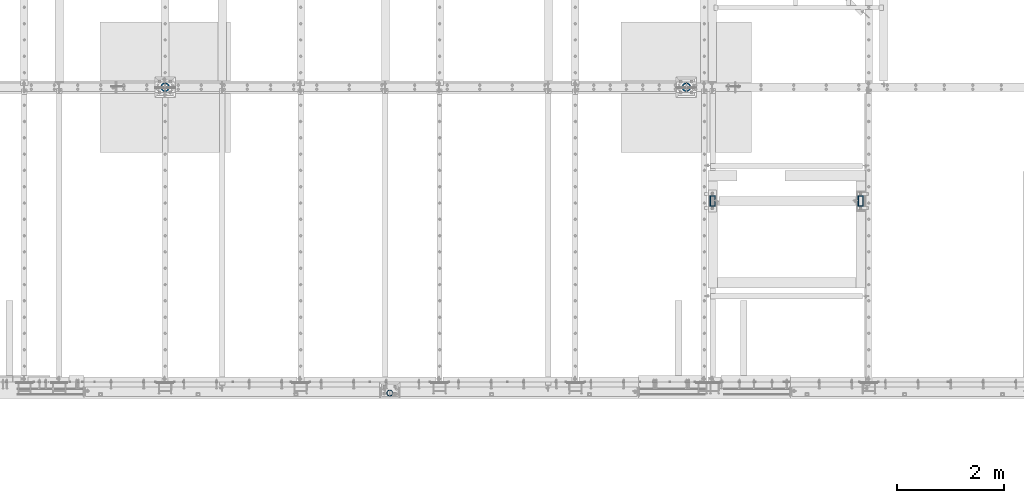
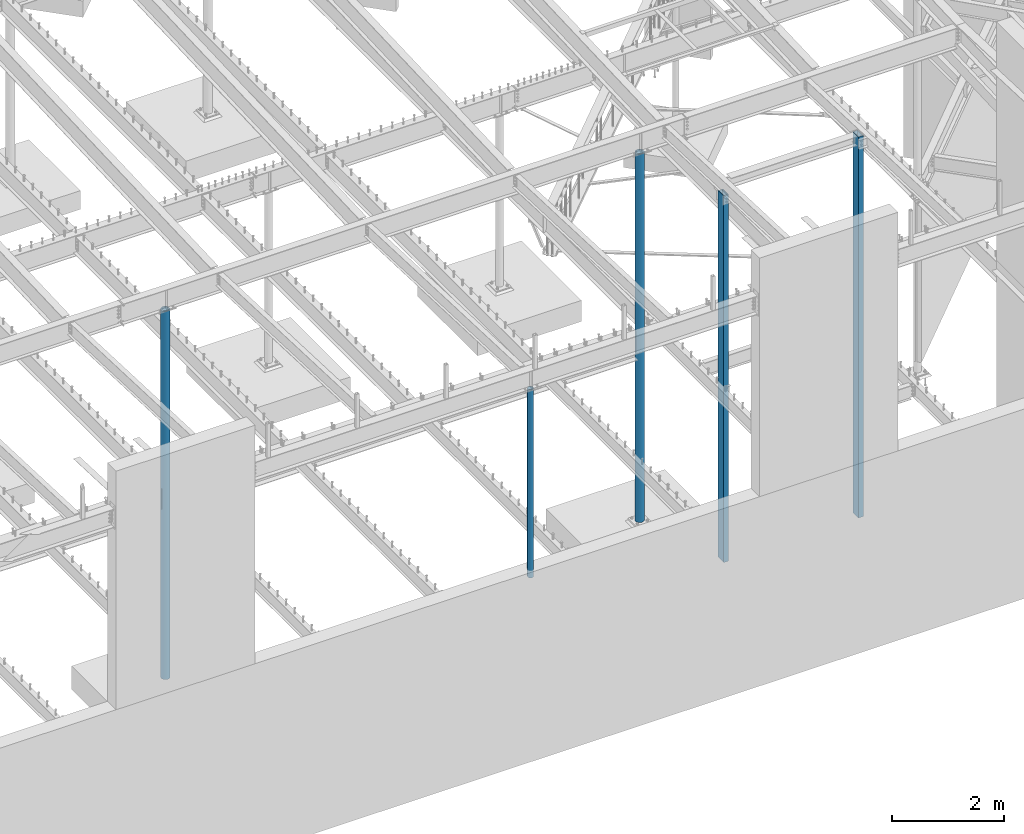
# One storey, part 122 of 975: 5 columns.
"""IFC2X3 building model written with IfcOpenShell, lengths in millimetres."""

import ifcopenshell
import ifcopenshell.guid

model = None  # the IFC model being written
_history = None  # IfcOwnerHistory: only IFC2X3 demands one
_inside = {}  # id of a spatial element -> (the spatial element, [elements in it])
_under = {}  # id of a project, library or spatial element -> (it, [spatial elements below it])
_declared = {}  # id of a project -> (the project, [libraries it declares])
_typed = {}  # id of a type object -> (the type object, [elements of that type])
_made_of = {}  # id of a material, layer set ... -> (it, [elements and type objects made of it])


def new_model(schema):
    """Start an empty IFC model of exactly this schema.

    Asked for "IFC4X3", IfcOpenShell would pick the latest addendum, in which some entities
    have other attributes; the version numbers below select the first issue.
    IFC2X3 requires an IfcOwnerHistory on every rooted entity: one is made here for all.
    """
    global model, _history
    if schema == "IFC4X3":
        model = ifcopenshell.file(schema_version=(4, 3, 0, 0))
    else:
        model = ifcopenshell.file(schema=schema)
    _inside.clear()
    _under.clear()
    _declared.clear()
    _typed.clear()
    _made_of.clear()
    _history = None
    if model.schema == "IFC2X3":
        org = make("IfcOrganization", Name="unknown")
        user = make(
            "IfcPersonAndOrganization",
            ThePerson=make("IfcPerson", FamilyName="unknown"),
            TheOrganization=org,
        )
        app = make(
            "IfcApplication",
            ApplicationDeveloper=org,
            Version="unknown",
            ApplicationFullName="unknown",
            ApplicationIdentifier="unknown",
        )
        _history = make(
            "IfcOwnerHistory",
            OwningUser=user,
            OwningApplication=app,
            ChangeAction="ADDED",
            CreationDate=0,
        )
    return model


def make(cls, **values):
    """One entity of the class cls with the attributes given. An attribute that is None is left unset."""
    return model.create_entity(
        cls, **{name: value for name, value in values.items() if value is not None}
    )


def rooted(cls, **values):
    """An entity with a GlobalId (a new one), such as an element, a storey or a relation."""
    return make(cls, GlobalId=ifcopenshell.guid.new(), OwnerHistory=_history, **values)


def si_unit(unit_type, name, prefix=None):
    """IfcSIUnit, for example si_unit("LENGTHUNIT", "METRE", prefix="MILLI")."""
    return make("IfcSIUnit", UnitType=unit_type, Prefix=prefix, Name=name)


def assignment(units):
    """IfcUnitAssignment: the units of a project."""
    return None if units is None else make("IfcUnitAssignment", Units=units)


def point(xyz):
    """IfcCartesianPoint."""
    return None if xyz is None else make("IfcCartesianPoint", Coordinates=xyz)


def direction(xyz):
    """IfcDirection."""
    return None if xyz is None else make("IfcDirection", DirectionRatios=xyz)


def frame(location, z_axis=None, x_axis=None):
    """IfcAxis2Placement3D, a coordinate frame: its origin and axes. An axis left out is left unset."""
    return make(
        "IfcAxis2Placement3D",
        Location=point(location),
        Axis=direction(z_axis),
        RefDirection=direction(x_axis),
    )


def origin_with_axes():
    """The frame at (0, 0, 0) with the z axis (0, 0, 1) and the x axis (1, 0, 0) written out."""
    return frame((0.0, 0.0, 0.0), z_axis=(0.0, 0.0, 1.0), x_axis=(1.0, 0.0, 0.0))


def place(relative_to, where):
    """IfcLocalPlacement: puts the frame where relative to a parent placement (None: the world)."""
    return make(
        "IfcLocalPlacement", PlacementRelTo=relative_to, RelativePlacement=where
    )


def context(
    kind, dimensions, precision=None, world=None, true_north=None, identifier=None
):
    """IfcGeometricRepresentationContext, for example the 3D "Model" context."""
    return make(
        "IfcGeometricRepresentationContext",
        ContextIdentifier=identifier,
        ContextType=kind,
        CoordinateSpaceDimension=dimensions,
        Precision=precision,
        WorldCoordinateSystem=world,
        TrueNorth=true_north,
    )


def subcontext(parent, identifier, kind, view, scale=None):
    """IfcGeometricRepresentationSubContext, for example "Body" below "Model"."""
    return make(
        "IfcGeometricRepresentationSubContext",
        ContextIdentifier=identifier,
        ContextType=kind,
        ParentContext=parent,
        TargetScale=scale,
        TargetView=view,
    )


def project(units=None, contexts=None):
    """IfcProject with its units and contexts."""
    return rooted(
        "IfcProject",
        Name="project",
        RepresentationContexts=contexts,
        UnitsInContext=assignment(units),
    )


def spatial(cls, under=None, at=None, **own):
    """A site, building, storey or space (cls), placed at a placement, below another one or the project."""
    s = rooted(cls, ObjectPlacement=at, **own)
    if under is not None:
        _under.setdefault(under.id(), (under, []))[1].append(s)
    return s


def faces_of(points, faces, orient=None, outer=None):
    """IfcFace entities. A face is a list of loops; a loop is a list of indices into points, from 0.

    orient and outer hold one flag for each loop. By default every Orientation is true, the
    first loop of a face is its IfcFaceOuterBound and the others are IfcFaceBound.
    """
    made = []
    for i, loops in enumerate(faces):
        bounds = []
        for j, loop in enumerate(loops):
            is_outer = j == 0 if outer is None else outer[i][j]
            bounds.append(
                make(
                    "IfcFaceOuterBound" if is_outer else "IfcFaceBound",
                    Bound=make("IfcPolyLoop", Polygon=[points[k] for k in loop]),
                    Orientation=True if orient is None else orient[i][j],
                )
            )
        made.append(make("IfcFace", Bounds=bounds))
    return made


def faceted_brep(points, faces, orient=None, outer=None, voids=None):
    """IfcFacetedBrep: a solid bounded by flat faces; with voids (closed shells), ...WithVoids."""
    shared = [point(p) for p in points]
    hull = make("IfcClosedShell", CfsFaces=faces_of(shared, faces, orient, outer))
    if voids is None:
        return make("IfcFacetedBrep", Outer=hull)
    return make(
        "IfcFacetedBrepWithVoids",
        Outer=hull,
        Voids=[
            make(cls, CfsFaces=faces_of(shared, fs, o, b)) for cls, fs, o, b in voids
        ],
    )


def shape(context_of_items, identifier, shape_type, items):
    """IfcShapeRepresentation: the items that make up one representation, for example the "Body"."""
    return make(
        "IfcShapeRepresentation",
        ContextOfItems=context_of_items,
        RepresentationIdentifier=identifier,
        RepresentationType=shape_type,
        Items=items,
    )


def material(Name=None, Category=None):
    """IfcMaterial."""
    return make("IfcMaterial", Name=Name, Category=Category)


def made_of(thing, what):
    """Note that an element or type object is made of a material, layer set ...; save() writes the relation."""
    if what is not None:
        _made_of.setdefault(what.id(), (what, []))[1].append(thing)
    return thing


def type_object(cls, material=None, **own):
    """A type object (cls), such as IfcWallType, which elements share."""
    return made_of(rooted(cls, **own), material)


def element(
    cls,
    number,
    at=None,
    inside=None,
    cuts=None,
    type_object=None,
    material=None,
    context=None,
    identifier="Body",
    shape_type=None,
    held_by="IfcProductDefinitionShape",
    body=None,
    shapes=None,
    **own,
):
    """One element of the class cls, such as IfcWall. Its Tag is "e" and its number.

    at: its placement. inside: the storey or other place that contains it. cuts: it is an
    opening in that element (IfcRelVoidsElement). A single representation is given by context,
    identifier, shape_type and body (its items); several are given by shapes. held_by: the class
    of the entity that holds the representations. save() writes the other relations.
    """
    e = rooted(cls, Tag="e%d" % number, ObjectPlacement=at, **own)
    if body is not None:
        shapes = [shape(context, identifier, shape_type, body)]
    if shapes is not None:
        e.Representation = make(held_by, Representations=shapes)
    if inside is not None:
        _inside.setdefault(inside.id(), (inside, []))[1].append(e)
    if cuts is not None:
        rooted(
            "IfcRelVoidsElement", RelatingBuildingElement=cuts, RelatedOpeningElement=e
        )
    if type_object is not None:
        _typed.setdefault(type_object.id(), (type_object, []))[1].append(e)
    return made_of(e, material)


def aggregate(whole, parts):
    """IfcRelAggregates: a whole, such as a stair, and the parts it consists of."""
    return rooted("IfcRelAggregates", RelatingObject=whole, RelatedObjects=parts)


def save(model, path):
    """Write the relations noted so far, then the file.

    IfcRelAggregates (storeys below a building ...), IfcRelContainedInSpatialStructure (elements
    in a storey), IfcRelDefinesByType, IfcRelAssociatesMaterial and IfcRelDeclares: one each for
    every whole, place, type object, material and project.
    """
    for whole, parts in _under.values():
        aggregate(whole, parts)
    for where, things in _inside.values():
        rooted(
            "IfcRelContainedInSpatialStructure",
            RelatedElements=things,
            RelatingStructure=where,
        )
    for kind, things in _typed.values():
        rooted("IfcRelDefinesByType", RelatedObjects=things, RelatingType=kind)
    for what, things in _made_of.values():
        rooted("IfcRelAssociatesMaterial", RelatedObjects=things, RelatingMaterial=what)
    for by, libraries in _declared.values():
        rooted("IfcRelDeclares", RelatingContext=by, RelatedDefinitions=libraries)
    model.write(path)


model = new_model("IFC2X3")

# Units and contexts
model_context = context("Model", 3, precision=1e-05, world=origin_with_axes())
body_context = subcontext(model_context, "Body", "Model", "MODEL_VIEW")
ifc_project = project(units=[si_unit("LENGTHUNIT", "METRE", prefix="MILLI"), si_unit("AREAUNIT", "SQUARE_METRE"), si_unit("VOLUMEUNIT", "CUBIC_METRE"), si_unit("MASSUNIT", "GRAM", prefix="KILO"), si_unit("TIMEUNIT", "SECOND"), si_unit("PLANEANGLEUNIT", "RADIAN"), si_unit("SOLIDANGLEUNIT", "STERADIAN"), si_unit("THERMODYNAMICTEMPERATUREUNIT", "DEGREE_CELSIUS"), si_unit("LUMINOUSINTENSITYUNIT", "LUMEN")], contexts=[model_context])

# Site, building, storey
site_placement = place(None, origin_with_axes())
site = spatial("IfcSite", under=ifc_project, at=site_placement, CompositionType="ELEMENT")
building_placement = place(site_placement, origin_with_axes())
building = spatial("IfcBuilding", under=site, at=building_placement, Name="Undefined", CompositionType="ELEMENT")
storey_placement = place(building_placement, origin_with_axes())
storey = spatial("IfcBuildingStorey", under=building, at=storey_placement, Name="Undefined", CompositionType="ELEMENT", Elevation=0.0)

# Columns
ifc_material_1 = material(Name="STEEL/A53")
column_type_1 = type_object("IfcColumnType", Name="PIPE4STD", PredefinedType="NOTDEFINED")
column_1_placement = place(storey_placement, frame((17687.9249973829, 101.599999669799, 3937.0), z_axis=(0.0, 1.0, 0.0), x_axis=(0.0, 0.0, 1.0)))
element("IfcColumn", 1, at=column_1_placement, inside=storey, type_object=column_type_1, material=ifc_material_1, Name="COLUMN", ObjectType="PIPE4STD", context=body_context, shape_type="Brep", body=[
    faceted_brep([(19.0500000000025, -51.1301999999996, 0.0), (19.0500000000025, -48.6277098894743, 15.8001007257917), (4105.275, -48.6277098894752, 15.8001007257899), (4105.275, -51.1301999999996, 0.0), (19.0500000000025, -41.3652007257897, 30.0535775067656), (4105.275, -41.3652007257915, 30.0535775067646), (19.0500000000025, -30.0535775067647, 41.3652007257915), (4105.275, -30.0535775067656, 41.3652007257899), (19.0500000000025, -15.8001007257899, 48.6277098894752), (4105.275, -15.8001007257917, 48.6277098894745), (19.0500000000025, 0.0, 51.1301999999996), (4105.275, 0.0, 51.1302), (19.0500000000025, 15.8001007257899, 48.6277098894752), (4105.275, 15.8001007257917, 48.6277098894745), (19.0500000000025, 30.0535775067647, 41.3652007257915), (4105.275, 30.0535775067656, 41.3652007257899), (19.0500000000025, 41.3652007257897, 30.0535775067656), (4105.275, 41.3652007257915, 30.0535775067646), (19.0500000000025, 48.6277098894743, 15.8001007257917), (4105.275, 48.6277098894752, 15.8001007257899), (19.0500000000025, 51.1301999999996, 0.0), (4105.275, 51.1301999999996, 0.0), (19.0500000000025, 48.6277098894743, -15.8001007257917), (4105.275, 48.6277098894752, -15.8001007257899), (19.0500000000025, 41.3652007257897, -30.0535775067656), (4105.275, 41.3652007257915, -30.0535775067646), (19.0500000000025, 30.0535775067647, -41.3652007257915), (4105.275, 30.0535775067656, -41.3652007257899), (19.0500000000025, 15.8001007257899, -48.6277098894752), (4105.275, 15.8001007257917, -48.6277098894745), (19.0500000000025, 0.0, -51.1301999999996), (4105.275, 0.0, -51.1302), (19.0500000000025, -15.8001007257899, -48.6277098894752), (4105.275, -15.8001007257917, -48.6277098894745), (19.0500000000025, -30.0535775067647, -41.3652007257915), (4105.275, -30.0535775067656, -41.3652007257899), (19.0500000000025, -41.3652007257897, -30.0535775067656), (4105.275, -41.3652007257915, -30.0535775067646), (19.0500000000025, -48.6277098894743, -15.8001007257917), (4105.275, -48.6277098894752, -15.8001007257899), (19.0500000000025, -57.1499999999996, 0.0), (19.0500000000025, -54.3528799062678, -17.6603212285299), (4105.275, -54.3528799062697, -17.6603212285283), (4105.275, -57.1500000000015, 0.0), (19.0500000000025, -46.2353212285279, -33.5919271685161), (4105.275, -46.235321228527, -33.5919271685148), (19.0500000000025, -33.5919271685152, -46.235321228527), (4105.275, -33.5919271685161, -46.2353212285282), (19.0500000000025, -17.6603212285281, -54.3528799062697), (4105.275, -17.6603212285299, -54.352879906268), (19.0500000000025, 0.0, -57.1500000000015), (4105.275, 0.0, -57.15), (19.0500000000025, 17.6603212285281, -54.3528799062697), (4105.275, 17.6603212285299, -54.352879906268), (19.0500000000025, 33.5919271685152, -46.235321228527), (4105.275, 33.5919271685161, -46.2353212285282), (19.0500000000025, 46.2353212285279, -33.5919271685161), (4105.275, 46.235321228527, -33.5919271685148), (19.0500000000025, 54.3528799062678, -17.6603212285299), (4105.275, 54.3528799062697, -17.6603212285282), (19.0500000000025, 57.1499999999996, 0.0), (4105.275, 57.1500000000015, 0.0), (19.0500000000025, 54.3528799062678, 17.6603212285299), (4105.275, 54.3528799062697, 17.6603212285282), (19.0500000000025, 46.2353212285279, 33.5919271685161), (4105.275, 46.235321228527, 33.5919271685148), (19.0500000000025, 33.5919271685152, 46.235321228527), (4105.275, 33.5919271685161, 46.2353212285282), (19.0500000000025, 17.6603212285281, 54.3528799062697), (4105.275, 17.6603212285299, 54.352879906268), (19.0500000000025, 0.0, 57.1500000000015), (4105.275, 0.0, 57.15), (19.0500000000025, -17.6603212285281, 54.3528799062697), (4105.275, -17.6603212285299, 54.352879906268), (19.0500000000025, -33.5919271685152, 46.235321228527), (4105.275, -33.5919271685161, 46.2353212285282), (19.0500000000025, -46.2353212285279, 33.5919271685161), (4105.275, -46.235321228527, 33.5919271685148), (19.0500000000025, -54.3528799062678, 17.6603212285299), (4105.275, -54.3528799062697, 17.6603212285282)], [[[0, 1, 2, 3]], [[1, 4, 5, 2]], [[4, 6, 7, 5]], [[6, 8, 9, 7]], [[8, 10, 11, 9]], [[10, 12, 13, 11]], [[12, 14, 15, 13]], [[14, 16, 17, 15]], [[16, 18, 19, 17]], [[18, 20, 21, 19]], [[20, 22, 23, 21]], [[22, 24, 25, 23]], [[24, 26, 27, 25]], [[26, 28, 29, 27]], [[28, 30, 31, 29]], [[30, 32, 33, 31]], [[32, 34, 35, 33]], [[34, 36, 37, 35]], [[36, 38, 39, 37]], [[38, 0, 3, 39]], [[40, 41, 42, 43]], [[41, 44, 45, 42]], [[44, 46, 47, 45]], [[46, 48, 49, 47]], [[48, 50, 51, 49]], [[50, 52, 53, 51]], [[52, 54, 55, 53]], [[54, 56, 57, 55]], [[56, 58, 59, 57]], [[58, 60, 61, 59]], [[60, 62, 63, 61]], [[62, 64, 65, 63]], [[64, 66, 67, 65]], [[66, 68, 69, 67]], [[68, 70, 71, 69]], [[70, 72, 73, 71]], [[72, 74, 75, 73]], [[74, 76, 77, 75]], [[76, 78, 79, 77]], [[78, 40, 43, 79]], [[45, 47, 49, 51, 53, 55, 57, 59, 61, 63, 65, 67, 69, 71, 73, 75, 77, 79, 43, 42], [5, 7, 9, 11, 13, 15, 17, 19, 21, 23, 25, 27, 29, 31, 33, 35, 37, 39, 3, 2]], [[78, 76, 74, 72, 70, 68, 66, 64, 62, 60, 58, 56, 54, 52, 50, 48, 46, 44, 41, 40], [38, 36, 34, 32, 30, 28, 26, 24, 22, 20, 18, 16, 14, 12, 10, 8, 6, 4, 1, 0]]]),
])
ifc_material_2 = material()
column_type_2 = type_object("IfcColumnType", Name="HSS8X4X1/2", PredefinedType="NOTDEFINED")
column_2_placement = place(storey_placement, frame((26492.2, 3690.93747558594, 0.0), z_axis=(0.0, -1.0, 0.0), x_axis=(0.0, 0.0, 1.0)))
element("IfcColumn", 2, at=column_2_placement, inside=storey, type_object=column_type_2, material=ifc_material_2, Name="COLUMN", ObjectType="HSS8X4X1/2", context=body_context, shape_type="Brep", body=[
    faceted_brep([(38.1000000000063, 38.0999999999985, -88.9000000000001), (38.1000000000063, -38.0999999999985, -88.9000000000001), (8308.73594882392, -38.0999999999985, -88.9000000000001), (8308.73594882392, 38.0999999999985, -88.9000000000001), (38.1000000000063, -38.0999999999985, 88.9000000000001), (8308.73594882392, -38.0999999999985, 88.9000000000001), (38.1000000000063, 38.0999999999985, 88.9000000000001), (8308.73594882392, 38.0999999999985, 88.9000000000001), (38.1000000000063, 50.7999999999993, -101.6), (38.1000000000063, 50.7999999999993, 101.6), (8308.73594882392, 50.7999999999993, 101.6), (8308.73594882392, 50.7999999999993, -101.6), (38.1000000000063, -50.7999999999993, 101.6), (8308.73594882392, -50.7999999999993, 101.6), (38.1000000000063, -50.7999999999993, -101.6), (8308.73594882392, -50.7999999999993, -101.6)], [[[0, 1, 2, 3]], [[1, 4, 5, 2]], [[4, 6, 7, 5]], [[6, 0, 3, 7]], [[8, 9, 10, 11]], [[9, 12, 13, 10]], [[12, 14, 15, 13]], [[14, 8, 11, 15]], [[13, 15, 11, 10], [5, 7, 3, 2]], [[14, 12, 9, 8], [6, 4, 1, 0]]]),
])
column_3_placement = place(storey_placement, frame((23723.5999908447, 3690.93747558594, 0.0), z_axis=(0.0, -1.0, 0.0), x_axis=(0.0, 0.0, 1.0)))
element("IfcColumn", 3, at=column_3_placement, inside=storey, type_object=column_type_2, material=ifc_material_2, Name="COLUMN", ObjectType="HSS8X4X1/2", context=body_context, shape_type="Brep", body=[
    faceted_brep([(38.1000000000063, 38.0999999999985, -88.9000000000001), (38.1000000000063, -38.0999999999985, -88.9000000000001), (7998.24772151669, -38.0999999999985, -88.9000000000001), (7998.24772151669, 38.0999999999985, -88.9000000000001), (38.1000000000063, -38.0999999999985, 88.9000000000001), (7998.24772151669, -38.0999999999985, 88.9000000000001), (38.1000000000063, 38.0999999999985, 88.9000000000001), (7998.24772151669, 38.0999999999985, 88.9000000000001), (38.1000000000063, 50.7999999999993, -101.6), (38.1000000000063, 50.7999999999993, 101.6), (7998.24772151669, 50.7999999999993, 101.6), (7998.24772151669, 50.7999999999993, -101.6), (38.1000000000063, -50.7999999999993, 101.6), (7998.24772151669, -50.7999999999993, 101.6), (38.1000000000063, -50.7999999999993, -101.6), (7998.24772151669, -50.7999999999993, -101.6)], [[[0, 1, 2, 3]], [[1, 4, 5, 2]], [[4, 6, 7, 5]], [[6, 0, 3, 7]], [[8, 9, 10, 11]], [[9, 12, 13, 10]], [[12, 14, 15, 13]], [[14, 8, 11, 15]], [[13, 15, 11, 10], [5, 7, 3, 2]], [[14, 12, 9, 8], [6, 4, 1, 0]]]),
])
column_type_3 = type_object("IfcColumnType", Name="PIPE6XXS", PredefinedType="NOTDEFINED")
column_4_placement = place(storey_placement, frame((23233.0625, 5819.775, -266.7), z_axis=(0.0, 1.0, 0.0), x_axis=(0.0, 0.0, 1.0)))
element("IfcColumn", 4, at=column_4_placement, inside=storey, type_object=column_type_3, material=ifc_material_1, Name="COLUMN", ObjectType="PIPE6XXS", context=body_context, shape_type="Brep", body=[
    faceted_brep([(4167.1875, 58.5887230499029, -19.84375), (4167.1875, 81.588520751, -19.84375), (3706.8125, 81.588520751, -19.84375), (3706.8125, 58.5887230499029, -19.84375), (3706.8125, 60.1340986859577, -16.1128831804754), (3706.8125, 83.6785041502008, -3.96875), (3706.8125, 61.7329041502016, -3.96875), (4167.1875, 83.6785041502008, -3.96875), (4167.1875, 61.7329041502016, -3.96875), (4167.1875, 60.1340986859577, -16.1128831804754), (34.9249999999998, 84.2010000000009, 0.0), (34.9249999999998, 81.3319204993641, 21.7928224166772), (8032.75, 81.3319204993641, 21.7928224166772), (8032.75, 84.2010000000009, 0.0), (34.9249999999998, 72.9202050240528, 42.1005000000005), (8032.75, 72.9202050240528, 42.1005000000005), (34.9249999999998, 59.5390980826887, 59.5390980826887), (8032.75, 59.5390980826887, 59.5390980826887), (34.9249999999998, 42.1005000000005, 72.9202050240538), (8032.75, 42.1005000000005, 72.9202050240538), (34.9249999999998, 21.792822416679, 81.3319204993659), (8032.75, 21.792822416679, 81.3319204993659), (34.9249999999998, 0.0, 84.201), (8032.75, 0.0, 84.201), (34.9249999999998, -21.792822416679, 81.3319204993659), (8032.75, -21.792822416679, 81.3319204993659), (34.9249999999998, -42.1005000000005, 72.9202050240538), (8032.75, -42.1005000000005, 72.9202050240538), (34.9249999999998, -59.5390980826887, 59.5390980826887), (8032.75, -59.5390980826887, 59.5390980826887), (34.9249999999998, -72.9202050240528, 42.1004999999996), (8032.75, -72.9202050240528, 42.1004999999996), (34.9249999999998, -81.3319204993641, 21.7928224166772), (8032.75, -81.3319204993641, 21.7928224166772), (34.9249999999998, -84.2010000000009, 0.0), (8032.75, -84.2010000000009, 0.0), (34.9249999999998, 72.9202050240528, -42.1004999999996), (34.9249999999998, 81.3319204993641, -21.7928224166772), (8032.75, 81.3319204993641, -21.7928224166772), (8032.75, 72.9202050240528, -42.1004999999996), (34.9249999999998, 59.5390980826887, -59.5390980826887), (8032.75, 59.5390980826887, -59.5390980826887), (34.9249999999998, 42.1005000000005, -72.9202050240538), (8032.75, 42.1005000000005, -72.9202050240538), (34.9249999999998, 21.792822416679, -81.3319204993659), (8032.75, 21.792822416679, -81.3319204993659), (34.9249999999998, 0.0, -84.201), (8032.75, 0.0, -84.201), (34.9249999999998, -21.792822416679, -81.3319204993659), (8032.75, -21.792822416679, -81.3319204993659), (34.9249999999998, -42.1005000000005, -72.9202050240538), (8032.75, -42.1005000000005, -72.9202050240538), (34.9249999999998, -59.5390980826887, -59.5390980826887), (8032.75, -59.5390980826887, -59.5390980826887), (34.9249999999998, -72.9202050240528, -42.1005000000005), (8032.75, -72.9202050240528, -42.1005000000005), (34.9249999999998, -81.3319204993641, -21.7928224166772), (8032.75, -81.3319204993641, -21.7928224166772), (3706.8125, -81.588520751, -19.84375), (3706.8125, -83.6785041502008, -3.96875), (4167.1875, -83.6785041502008, -3.96875), (4167.1875, -81.588520751, -19.84375), (34.9249999999998, -60.1340986859577, -16.1128831804754), (34.9249999999998, -53.9147579227611, -31.1277), (34.9249999999998, -44.0212155054796, -44.0212155054805), (34.9249999999998, -31.1277000000009, -53.914757922762), (34.9249999999998, -16.1128831804745, -60.1340986859568), (34.9249999999998, 0.0, -62.2554), (34.9249999999998, 16.1128831804745, -60.1340986859568), (34.9249999999998, 31.1277000000009, -53.914757922762), (34.9249999999998, 44.0212155054796, -44.0212155054805), (34.9249999999998, 53.9147579227611, -31.1277), (34.9249999999998, 60.1340986859577, -16.1128831804754), (34.9249999999998, 62.2553999999982, 0.0), (34.9249999999998, 60.1340986859577, 16.1128831804754), (34.9249999999998, 53.9147579227611, 31.1277), (34.9249999999998, 44.0212155054796, 44.0212155054805), (34.9249999999998, 31.1277000000009, 53.914757922762), (34.9249999999998, 16.1128831804745, 60.1340986859568), (34.9249999999998, 0.0, 62.2554), (34.9249999999998, -16.1128831804745, 60.1340986859568), (34.9249999999998, -31.1277000000009, 53.914757922762), (34.9249999999998, -44.0212155054796, 44.0212155054815), (34.9249999999998, -53.9147579227611, 31.1277), (34.9249999999998, -60.1340986859577, 16.1128831804754), (34.9249999999998, -62.2553999999982, 0.0), (3706.8125, -60.1340986859577, -16.1128831804754), (8032.75, -62.2553999999982, 0.0), (8032.75, -60.1340986859577, -16.1128831804754), (4167.1875, -60.1340986859577, -16.1128831804754), (4167.1875, -61.7329041502016, -3.96875), (3706.8125, -61.7329041502016, -3.96875), (3706.8125, -58.5887230499029, -19.84375), (4167.1875, -58.5887230499029, -19.84375), (8032.75, -53.9147579227611, -31.1277), (8032.75, -44.0212155054796, -44.0212155054805), (8032.75, -31.1277000000009, -53.914757922762), (8032.75, -16.1128831804745, -60.1340986859568), (8032.75, 0.0, -62.2554), (8032.75, 16.1128831804745, -60.1340986859568), (8032.75, 31.1277000000009, -53.914757922762), (8032.75, 44.0212155054796, -44.0212155054805), (8032.75, 53.9147579227611, -31.1277), (8032.75, 60.1340986859577, -16.1128831804754), (8032.75, 62.2553999999982, 0.0), (8032.75, 60.1340986859577, 16.1128831804754), (8032.75, 53.9147579227611, 31.1277), (8032.75, 44.0212155054796, 44.0212155054805), (8032.75, 31.1277000000009, 53.914757922762), (8032.75, 16.1128831804745, 60.1340986859568), (8032.75, 0.0, 62.2554), (8032.75, -16.1128831804745, 60.1340986859568), (8032.75, -31.1277000000009, 53.914757922762), (8032.75, -44.0212155054796, 44.0212155054815), (8032.75, -53.9147579227611, 31.1277), (8032.75, -60.1340986859577, 16.1128831804754)], [[[0, 1, 2, 3]], [[4, 3, 2, 5, 6]], [[6, 5, 7, 8]], [[8, 7, 1, 0, 9]], [[10, 11, 12, 13]], [[11, 14, 15, 12]], [[14, 16, 17, 15]], [[16, 18, 19, 17]], [[18, 20, 21, 19]], [[20, 22, 23, 21]], [[22, 24, 25, 23]], [[24, 26, 27, 25]], [[26, 28, 29, 27]], [[28, 30, 31, 29]], [[30, 32, 33, 31]], [[32, 34, 35, 33]], [[36, 37, 38, 39]], [[40, 36, 39, 41]], [[42, 40, 41, 43]], [[44, 42, 43, 45]], [[46, 44, 45, 47]], [[48, 46, 47, 49]], [[50, 48, 49, 51]], [[52, 50, 51, 53]], [[54, 52, 53, 55]], [[56, 54, 55, 57]], [[34, 56, 57, 35], [58, 59, 60, 61]], [[32, 30, 28, 26, 24, 22, 20, 18, 16, 14, 11, 10, 37, 36, 40, 42, 44, 46, 48, 50, 52, 54, 56, 34], [62, 63, 64, 65, 66, 67, 68, 69, 70, 71, 72, 73, 74, 75, 76, 77, 78, 79, 80, 81, 82, 83, 84, 85]], [[86, 62, 85, 87, 88, 89, 90, 91]], [[59, 91, 90, 60]], [[58, 92, 86, 91, 59]], [[61, 93, 92, 58]], [[60, 90, 89, 93, 61]], [[88, 94, 63, 62, 86, 92, 93, 89]], [[64, 63, 94, 95]], [[65, 64, 95, 96]], [[66, 65, 96, 97]], [[67, 66, 97, 98]], [[68, 67, 98, 99]], [[69, 68, 99, 100]], [[70, 69, 100, 101]], [[71, 70, 101, 102]], [[3, 4, 72, 71, 102, 103, 9, 0]], [[103, 104, 73, 72, 4, 6, 8, 9]], [[74, 73, 104, 105]], [[75, 74, 105, 106]], [[76, 75, 106, 107]], [[77, 76, 107, 108]], [[78, 77, 108, 109]], [[79, 78, 109, 110]], [[80, 79, 110, 111]], [[81, 80, 111, 112]], [[82, 81, 112, 113]], [[83, 82, 113, 114]], [[84, 83, 114, 115]], [[85, 84, 115, 87]], [[55, 53, 51, 49, 47, 45, 43, 41, 39, 38, 13, 12, 15, 17, 19, 21, 23, 25, 27, 29, 31, 33, 35, 57], [114, 113, 112, 111, 110, 109, 108, 107, 106, 105, 104, 103, 102, 101, 100, 99, 98, 97, 96, 95, 94, 88, 87, 115]], [[37, 10, 13, 38], [2, 1, 7, 5]]]),
])
column_5_placement = place(storey_placement, frame((13487.4, 5819.775, -266.7), z_axis=(0.0, 1.0, 0.0), x_axis=(0.0, 0.0, 1.0)))
element("IfcColumn", 5, at=column_5_placement, inside=storey, type_object=column_type_3, material=ifc_material_1, Name="COLUMN", ObjectType="PIPE6XXS", context=body_context, shape_type="Brep", body=[
    faceted_brep([(4167.1875, 58.5887230499029, -19.84375), (4167.1875, 81.588520751, -19.84375), (3706.8125, 81.588520751, -19.84375), (3706.8125, 58.5887230499029, -19.84375), (3706.8125, 60.1340986859577, -16.1128831804754), (3706.8125, 83.6785041502008, -3.96875), (3706.8125, 61.7329041502016, -3.96875), (4167.1875, 83.6785041502008, -3.96875), (4167.1875, 61.7329041502016, -3.96875), (4167.1875, 60.1340986859577, -16.1128831804754), (34.9249999999998, 84.2010000000009, 0.0), (34.9249999999998, 81.3319204993641, 21.7928224166772), (8032.75, 81.3319204993641, 21.7928224166772), (8032.75, 84.2010000000009, 0.0), (34.9249999999998, 72.9202050240528, 42.1005000000005), (8032.75, 72.9202050240528, 42.1005000000005), (34.9249999999998, 59.5390980826887, 59.5390980826887), (8032.75, 59.5390980826887, 59.5390980826887), (34.9249999999998, 42.1005000000005, 72.9202050240538), (8032.75, 42.1005000000005, 72.9202050240538), (34.9249999999998, 21.792822416679, 81.3319204993659), (8032.75, 21.792822416679, 81.3319204993659), (34.9249999999998, 0.0, 84.201), (8032.75, 0.0, 84.201), (34.9249999999998, -21.792822416679, 81.3319204993659), (8032.75, -21.792822416679, 81.3319204993659), (34.9249999999998, -42.1005000000005, 72.9202050240538), (8032.75, -42.1005000000005, 72.9202050240538), (34.9249999999998, -59.5390980826887, 59.5390980826887), (8032.75, -59.5390980826887, 59.5390980826887), (34.9249999999998, -72.9202050240528, 42.1004999999996), (8032.75, -72.9202050240528, 42.1004999999996), (34.9249999999998, -81.3319204993641, 21.7928224166772), (8032.75, -81.3319204993641, 21.7928224166772), (34.9249999999998, -84.2010000000009, 0.0), (8032.75, -84.2010000000009, 0.0), (34.9249999999998, 72.9202050240528, -42.1004999999996), (34.9249999999998, 81.3319204993641, -21.7928224166772), (8032.75, 81.3319204993641, -21.7928224166772), (8032.75, 72.9202050240528, -42.1004999999996), (34.9249999999998, 59.5390980826887, -59.5390980826887), (8032.75, 59.5390980826887, -59.5390980826887), (34.9249999999998, 42.1005000000005, -72.9202050240538), (8032.75, 42.1005000000005, -72.9202050240538), (34.9249999999998, 21.792822416679, -81.3319204993659), (8032.75, 21.792822416679, -81.3319204993659), (34.9249999999998, 0.0, -84.201), (8032.75, 0.0, -84.201), (34.9249999999998, -21.792822416679, -81.3319204993659), (8032.75, -21.792822416679, -81.3319204993659), (34.9249999999998, -42.1005000000005, -72.9202050240538), (8032.75, -42.1005000000005, -72.9202050240538), (34.9249999999998, -59.5390980826887, -59.5390980826887), (8032.75, -59.5390980826887, -59.5390980826887), (34.9249999999998, -72.9202050240528, -42.1005000000005), (8032.75, -72.9202050240528, -42.1005000000005), (34.9249999999998, -81.3319204993641, -21.7928224166772), (8032.75, -81.3319204993641, -21.7928224166772), (3706.8125, -81.588520751, -19.84375), (3706.8125, -83.6785041502008, -3.96875), (4167.1875, -83.6785041502008, -3.96875), (4167.1875, -81.588520751, -19.84375), (34.9249999999998, -60.1340986859577, -16.1128831804754), (34.9249999999998, -53.9147579227611, -31.1277), (34.9249999999998, -44.0212155054796, -44.0212155054805), (34.9249999999998, -31.1277000000009, -53.914757922762), (34.9249999999998, -16.1128831804745, -60.1340986859568), (34.9249999999998, 0.0, -62.2554), (34.9249999999998, 16.1128831804745, -60.1340986859568), (34.9249999999998, 31.1277000000009, -53.914757922762), (34.9249999999998, 44.0212155054796, -44.0212155054805), (34.9249999999998, 53.9147579227611, -31.1277), (34.9249999999998, 60.1340986859577, -16.1128831804754), (34.9249999999998, 62.2553999999982, 0.0), (34.9249999999998, 60.1340986859577, 16.1128831804754), (34.9249999999998, 53.9147579227611, 31.1277), (34.9249999999998, 44.0212155054796, 44.0212155054805), (34.9249999999998, 31.1277000000009, 53.914757922762), (34.9249999999998, 16.1128831804745, 60.1340986859568), (34.9249999999998, 0.0, 62.2554), (34.9249999999998, -16.1128831804745, 60.1340986859568), (34.9249999999998, -31.1277000000009, 53.914757922762), (34.9249999999998, -44.0212155054796, 44.0212155054815), (34.9249999999998, -53.9147579227611, 31.1277), (34.9249999999998, -60.1340986859577, 16.1128831804754), (34.9249999999998, -62.2553999999982, 0.0), (3706.8125, -60.1340986859577, -16.1128831804754), (8032.75, -62.2553999999982, 0.0), (8032.75, -60.1340986859577, -16.1128831804754), (4167.1875, -60.1340986859577, -16.1128831804754), (4167.1875, -61.7329041502016, -3.96875), (3706.8125, -61.7329041502016, -3.96875), (3706.8125, -58.5887230499029, -19.84375), (4167.1875, -58.5887230499029, -19.84375), (8032.75, -53.9147579227611, -31.1277), (8032.75, -44.0212155054796, -44.0212155054805), (8032.75, -31.1277000000009, -53.914757922762), (8032.75, -16.1128831804745, -60.1340986859568), (8032.75, 0.0, -62.2554), (8032.75, 16.1128831804745, -60.1340986859568), (8032.75, 31.1277000000009, -53.914757922762), (8032.75, 44.0212155054796, -44.0212155054805), (8032.75, 53.9147579227611, -31.1277), (8032.75, 60.1340986859577, -16.1128831804754), (8032.75, 62.2553999999982, 0.0), (8032.75, 60.1340986859577, 16.1128831804754), (8032.75, 53.9147579227611, 31.1277), (8032.75, 44.0212155054796, 44.0212155054805), (8032.75, 31.1277000000009, 53.914757922762), (8032.75, 16.1128831804745, 60.1340986859568), (8032.75, 0.0, 62.2554), (8032.75, -16.1128831804745, 60.1340986859568), (8032.75, -31.1277000000009, 53.914757922762), (8032.75, -44.0212155054796, 44.0212155054815), (8032.75, -53.9147579227611, 31.1277), (8032.75, -60.1340986859577, 16.1128831804754)], [[[0, 1, 2, 3]], [[4, 3, 2, 5, 6]], [[6, 5, 7, 8]], [[8, 7, 1, 0, 9]], [[10, 11, 12, 13]], [[11, 14, 15, 12]], [[14, 16, 17, 15]], [[16, 18, 19, 17]], [[18, 20, 21, 19]], [[20, 22, 23, 21]], [[22, 24, 25, 23]], [[24, 26, 27, 25]], [[26, 28, 29, 27]], [[28, 30, 31, 29]], [[30, 32, 33, 31]], [[32, 34, 35, 33]], [[36, 37, 38, 39]], [[40, 36, 39, 41]], [[42, 40, 41, 43]], [[44, 42, 43, 45]], [[46, 44, 45, 47]], [[48, 46, 47, 49]], [[50, 48, 49, 51]], [[52, 50, 51, 53]], [[54, 52, 53, 55]], [[56, 54, 55, 57]], [[34, 56, 57, 35], [58, 59, 60, 61]], [[32, 30, 28, 26, 24, 22, 20, 18, 16, 14, 11, 10, 37, 36, 40, 42, 44, 46, 48, 50, 52, 54, 56, 34], [62, 63, 64, 65, 66, 67, 68, 69, 70, 71, 72, 73, 74, 75, 76, 77, 78, 79, 80, 81, 82, 83, 84, 85]], [[86, 62, 85, 87, 88, 89, 90, 91]], [[59, 91, 90, 60]], [[58, 92, 86, 91, 59]], [[61, 93, 92, 58]], [[60, 90, 89, 93, 61]], [[88, 94, 63, 62, 86, 92, 93, 89]], [[64, 63, 94, 95]], [[65, 64, 95, 96]], [[66, 65, 96, 97]], [[67, 66, 97, 98]], [[68, 67, 98, 99]], [[69, 68, 99, 100]], [[70, 69, 100, 101]], [[71, 70, 101, 102]], [[3, 4, 72, 71, 102, 103, 9, 0]], [[103, 104, 73, 72, 4, 6, 8, 9]], [[74, 73, 104, 105]], [[75, 74, 105, 106]], [[76, 75, 106, 107]], [[77, 76, 107, 108]], [[78, 77, 108, 109]], [[79, 78, 109, 110]], [[80, 79, 110, 111]], [[81, 80, 111, 112]], [[82, 81, 112, 113]], [[83, 82, 113, 114]], [[84, 83, 114, 115]], [[85, 84, 115, 87]], [[55, 53, 51, 49, 47, 45, 43, 41, 39, 38, 13, 12, 15, 17, 19, 21, 23, 25, 27, 29, 31, 33, 35, 57], [114, 113, 112, 111, 110, 109, 108, 107, 106, 105, 104, 103, 102, 101, 100, 99, 98, 97, 96, 95, 94, 88, 87, 115]], [[37, 10, 13, 38], [2, 1, 7, 5]]]),
])

save(model, "model.ifc")
